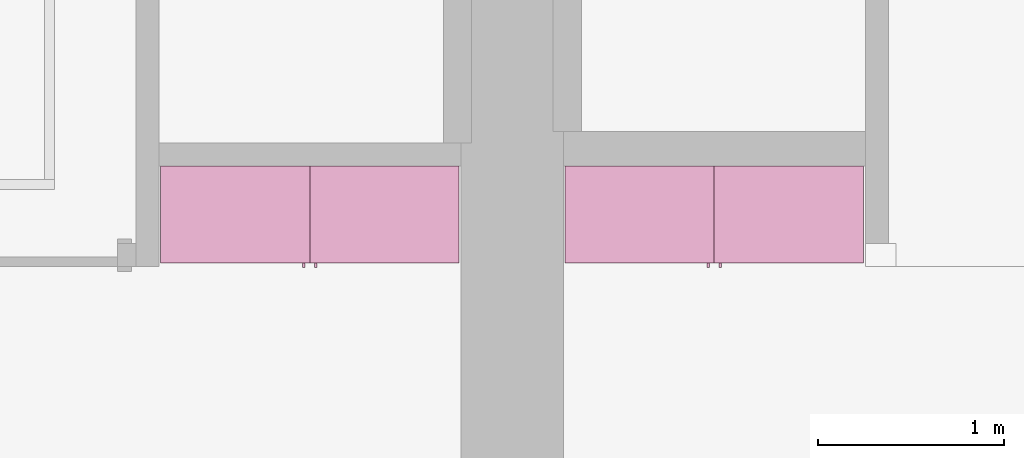
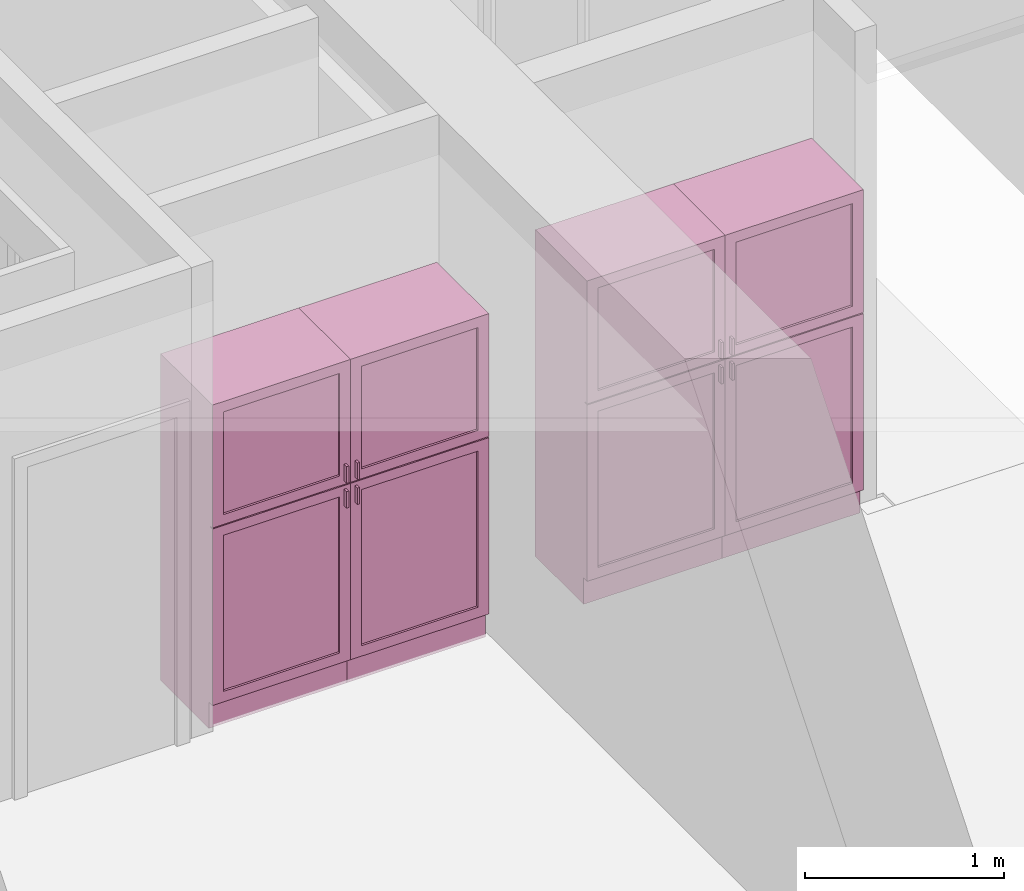
# One storey, part 11 of 12: 4 furnishings, 4 openings.
"""IFC2X3 building model written with IfcOpenShell, lengths in metres."""

import ifcopenshell
import ifcopenshell.guid

model = None  # the IFC model being written
_history = None  # IfcOwnerHistory: only IFC2X3 demands one
_inside = {}  # id of a spatial element -> (the spatial element, [elements in it])
_under = {}  # id of a project, library or spatial element -> (it, [spatial elements below it])
_declared = {}  # id of a project -> (the project, [libraries it declares])
_typed = {}  # id of a type object -> (the type object, [elements of that type])
_made_of = {}  # id of a material, layer set ... -> (it, [elements and type objects made of it])


def new_model(schema):
    """Start an empty IFC model of exactly this schema.

    Asked for "IFC4X3", IfcOpenShell would pick the latest addendum, in which some entities
    have other attributes; the version numbers below select the first issue.
    IFC2X3 requires an IfcOwnerHistory on every rooted entity: one is made here for all.
    """
    global model, _history
    if schema == "IFC4X3":
        model = ifcopenshell.file(schema_version=(4, 3, 0, 0))
    else:
        model = ifcopenshell.file(schema=schema)
    _inside.clear()
    _under.clear()
    _declared.clear()
    _typed.clear()
    _made_of.clear()
    _history = None
    if model.schema == "IFC2X3":
        org = make("IfcOrganization", Name="unknown")
        user = make(
            "IfcPersonAndOrganization",
            ThePerson=make("IfcPerson", FamilyName="unknown"),
            TheOrganization=org,
        )
        app = make(
            "IfcApplication",
            ApplicationDeveloper=org,
            Version="unknown",
            ApplicationFullName="unknown",
            ApplicationIdentifier="unknown",
        )
        _history = make(
            "IfcOwnerHistory",
            OwningUser=user,
            OwningApplication=app,
            ChangeAction="ADDED",
            CreationDate=0,
        )
    return model


def make(cls, **values):
    """One entity of the class cls with the attributes given. An attribute that is None is left unset."""
    return model.create_entity(
        cls, **{name: value for name, value in values.items() if value is not None}
    )


def entity(cls, *values):
    """Any entity or typed value of the class cls, its attributes in the order of the schema. None: left unset."""
    e = model.create_entity(cls)
    for i, value in enumerate(values):
        if value is not None:
            e[i] = value
    return e


def rooted(cls, **values):
    """An entity with a GlobalId (a new one), such as an element, a storey or a relation."""
    return make(cls, GlobalId=ifcopenshell.guid.new(), OwnerHistory=_history, **values)


def si_unit(unit_type, name, prefix=None):
    """IfcSIUnit, for example si_unit("LENGTHUNIT", "METRE", prefix="MILLI")."""
    return make("IfcSIUnit", UnitType=unit_type, Prefix=prefix, Name=name)


def converted_unit(unit_type, name, factor, base, dimensions=None, offset=None):
    """IfcConversionBasedUnit, such as the inch: factor (a typed value) times the base unit."""
    return make(
        "IfcConversionBasedUnit"
        if offset is None
        else "IfcConversionBasedUnitWithOffset",
        ConversionOffset=offset,
        Dimensions=None
        if dimensions is None
        else entity("IfcDimensionalExponents", *dimensions),
        UnitType=unit_type,
        Name=name,
        ConversionFactor=make(
            "IfcMeasureWithUnit", ValueComponent=factor, UnitComponent=base
        ),
    )


def assignment(units):
    """IfcUnitAssignment: the units of a project."""
    return None if units is None else make("IfcUnitAssignment", Units=units)


def point(xyz):
    """IfcCartesianPoint."""
    return None if xyz is None else make("IfcCartesianPoint", Coordinates=xyz)


def direction(xyz):
    """IfcDirection."""
    return None if xyz is None else make("IfcDirection", DirectionRatios=xyz)


def frame(location, z_axis=None, x_axis=None):
    """IfcAxis2Placement3D, a coordinate frame: its origin and axes. An axis left out is left unset."""
    return make(
        "IfcAxis2Placement3D",
        Location=point(location),
        Axis=direction(z_axis),
        RefDirection=direction(x_axis),
    )


def frame_2d(location, x_axis=None):
    """IfcAxis2Placement2D, a coordinate frame in the plane: its origin and x axis."""
    return make(
        "IfcAxis2Placement2D", Location=point(location), RefDirection=direction(x_axis)
    )


def origin():
    """The frame at (0, 0, 0) with its axes left unset."""
    return frame((0.0, 0.0, 0.0))


def origin_2d_with_axis():
    """The frame at (0, 0) in the plane with the x axis (1, 0) written out."""
    return frame_2d((0.0, 0.0), x_axis=(1.0, 0.0))


def place(relative_to, where):
    """IfcLocalPlacement: puts the frame where relative to a parent placement (None: the world)."""
    return make(
        "IfcLocalPlacement", PlacementRelTo=relative_to, RelativePlacement=where
    )


def context(
    kind, dimensions, precision=None, world=None, true_north=None, identifier=None
):
    """IfcGeometricRepresentationContext, for example the 3D "Model" context."""
    return make(
        "IfcGeometricRepresentationContext",
        ContextIdentifier=identifier,
        ContextType=kind,
        CoordinateSpaceDimension=dimensions,
        Precision=precision,
        WorldCoordinateSystem=world,
        TrueNorth=true_north,
    )


def project(units=None, contexts=None):
    """IfcProject with its units and contexts."""
    return rooted(
        "IfcProject",
        Name="project",
        RepresentationContexts=contexts,
        UnitsInContext=assignment(units),
    )


def spatial(cls, under=None, at=None, **own):
    """A site, building, storey or space (cls), placed at a placement, below another one or the project."""
    s = rooted(cls, ObjectPlacement=at, **own)
    if under is not None:
        _under.setdefault(under.id(), (under, []))[1].append(s)
    return s


def profile(cls, at=None, kind="AREA", **sizes):
    """A parametric profile (cls). Its sizes go by their IFC names, for example OverallWidth=200.0."""
    return make(cls, ProfileType=kind, Position=at, **sizes)


def rectangle(**sizes):
    """IfcRectangleProfileDef."""
    return profile("IfcRectangleProfileDef", **sizes)


def extrude(swept, where, along, depth):
    """IfcExtrudedAreaSolid: the profile swept, set in the frame where, extruded along a direction by depth."""
    return make(
        "IfcExtrudedAreaSolid",
        SweptArea=swept,
        Position=where,
        ExtrudedDirection=direction(along),
        Depth=depth,
    )


def faces_of(points, faces, orient=None, outer=None):
    """IfcFace entities. A face is a list of loops; a loop is a list of indices into points, from 0.

    orient and outer hold one flag for each loop. By default every Orientation is true, the
    first loop of a face is its IfcFaceOuterBound and the others are IfcFaceBound.
    """
    made = []
    for i, loops in enumerate(faces):
        bounds = []
        for j, loop in enumerate(loops):
            is_outer = j == 0 if outer is None else outer[i][j]
            bounds.append(
                make(
                    "IfcFaceOuterBound" if is_outer else "IfcFaceBound",
                    Bound=make("IfcPolyLoop", Polygon=[points[k] for k in loop]),
                    Orientation=True if orient is None else orient[i][j],
                )
            )
        made.append(make("IfcFace", Bounds=bounds))
    return made


def face_set(faces, orient=None, outer=None):
    """The faces of one IfcConnectedFaceSet. surface_model builds it on its shared points."""
    return ("IfcConnectedFaceSet", faces, orient, outer)


def surface_model(cls, points, shells):
    """IfcFaceBasedSurfaceModel or IfcShellBasedSurfaceModel (cls): surfaces that need not close."""
    shared = [point(p) for p in points]
    made = [make(c, CfsFaces=faces_of(shared, fs, o, b)) for c, fs, o, b in shells]
    if cls == "IfcFaceBasedSurfaceModel":
        return make(cls, FbsmFaces=made)
    return make(cls, SbsmBoundary=made)


def shape(context_of_items, identifier, shape_type, items):
    """IfcShapeRepresentation: the items that make up one representation, for example the "Body"."""
    return make(
        "IfcShapeRepresentation",
        ContextOfItems=context_of_items,
        RepresentationIdentifier=identifier,
        RepresentationType=shape_type,
        Items=items,
    )


def source(mapping_origin, context_of_items, identifier, shape_type, items):
    """IfcRepresentationMap: a shape defined once, which mapped items show again and again."""
    return make(
        "IfcRepresentationMap",
        MappingOrigin=mapping_origin,
        MappedRepresentation=shape(context_of_items, identifier, shape_type, items),
    )


def transform(
    local_origin,
    x_axis=None,
    y_axis=None,
    z_axis=None,
    scale=None,
    scale2=None,
    scale3=None,
    uniform=True,
):
    """IfcCartesianTransformationOperator3D, or its non-uniform kind. x_axis, y_axis, z_axis: its Axis1, 2, 3."""
    if uniform:
        return make(
            "IfcCartesianTransformationOperator3D",
            Axis1=direction(x_axis),
            Axis2=direction(y_axis),
            LocalOrigin=point(local_origin),
            Scale=scale,
            Axis3=direction(z_axis),
        )
    return make(
        "IfcCartesianTransformationOperator3DnonUniform",
        Axis1=direction(x_axis),
        Axis2=direction(y_axis),
        LocalOrigin=point(local_origin),
        Scale=scale,
        Axis3=direction(z_axis),
        Scale2=scale2,
        Scale3=scale3,
    )


def mapped(mapping_source, mapping_target):
    """IfcMappedItem: shows the shape of a source again, moved by a transform."""
    return make(
        "IfcMappedItem", MappingSource=mapping_source, MappingTarget=mapping_target
    )


def made_of(thing, what):
    """Note that an element or type object is made of a material, layer set ...; save() writes the relation."""
    if what is not None:
        _made_of.setdefault(what.id(), (what, []))[1].append(thing)
    return thing


def type_object(cls, material=None, **own):
    """A type object (cls), such as IfcWallType, which elements share."""
    return made_of(rooted(cls, **own), material)


def type_shapes(of_type, sources):
    """Give a type object the sources (RepresentationMaps) that its elements show as mapped items."""
    of_type.RepresentationMaps = sources


def element(
    cls,
    number,
    at=None,
    inside=None,
    cuts=None,
    type_object=None,
    material=None,
    context=None,
    identifier="Body",
    shape_type=None,
    held_by="IfcProductDefinitionShape",
    body=None,
    shapes=None,
    **own,
):
    """One element of the class cls, such as IfcWall. Its Tag is "e" and its number.

    at: its placement. inside: the storey or other place that contains it. cuts: it is an
    opening in that element (IfcRelVoidsElement). A single representation is given by context,
    identifier, shape_type and body (its items); several are given by shapes. held_by: the class
    of the entity that holds the representations. save() writes the other relations.
    """
    e = rooted(cls, Tag="e%d" % number, ObjectPlacement=at, **own)
    if body is not None:
        shapes = [shape(context, identifier, shape_type, body)]
    if shapes is not None:
        e.Representation = make(held_by, Representations=shapes)
    if inside is not None:
        _inside.setdefault(inside.id(), (inside, []))[1].append(e)
    if cuts is not None:
        rooted(
            "IfcRelVoidsElement", RelatingBuildingElement=cuts, RelatedOpeningElement=e
        )
    if type_object is not None:
        _typed.setdefault(type_object.id(), (type_object, []))[1].append(e)
    return made_of(e, material)


def aggregate(whole, parts):
    """IfcRelAggregates: a whole, such as a stair, and the parts it consists of."""
    return rooted("IfcRelAggregates", RelatingObject=whole, RelatedObjects=parts)


def save(model, path):
    """Write the relations noted so far, then the file.

    IfcRelAggregates (storeys below a building ...), IfcRelContainedInSpatialStructure (elements
    in a storey), IfcRelDefinesByType, IfcRelAssociatesMaterial and IfcRelDeclares: one each for
    every whole, place, type object, material and project.
    """
    for whole, parts in _under.values():
        aggregate(whole, parts)
    for where, things in _inside.values():
        rooted(
            "IfcRelContainedInSpatialStructure",
            RelatedElements=things,
            RelatingStructure=where,
        )
    for kind, things in _typed.values():
        rooted("IfcRelDefinesByType", RelatedObjects=things, RelatingType=kind)
    for what, things in _made_of.values():
        rooted("IfcRelAssociatesMaterial", RelatedObjects=things, RelatingMaterial=what)
    for by, libraries in _declared.values():
        rooted("IfcRelDeclares", RelatingContext=by, RelatedDefinitions=libraries)
    model.write(path)


model = new_model("IFC2X3")

# Units and contexts
model_context = context("Model", 3, precision=1e-09, world=origin())
plan_context = context("Plan", 3, precision=1e-09, world=origin())
ifc_project = project(units=[si_unit("LENGTHUNIT", "METRE"), si_unit("AREAUNIT", "SQUARE_METRE"), si_unit("VOLUMEUNIT", "CUBIC_METRE"), converted_unit("PLANEANGLEUNIT", "DEGREE", entity("IfcRatioMeasure", 0.0174532925199433), si_unit("PLANEANGLEUNIT", "RADIAN"), dimensions=[0, 0, 0, 0, 0, 0, 0]), si_unit("TIMEUNIT", "SECOND")], contexts=[model_context, plan_context])

# Site, building, storey, space
site_placement = place(None, origin())
site = spatial("IfcSite", under=ifc_project, at=site_placement, CompositionType="ELEMENT")
building_placement = place(site_placement, origin())
building = spatial("IfcBuilding", under=site, at=building_placement, CompositionType="ELEMENT")
storey_placement = place(building_placement, frame((0.0, 0.0, 3.10000000000038)))
storey = spatial("IfcBuildingStorey", under=building, at=storey_placement, Name="Level 2", CompositionType="ELEMENT", Elevation=3.10000000000038)
space_1_placement = place(storey_placement, origin())
space_1 = spatial("IfcSpace", under=storey, at=space_1_placement, CompositionType="ELEMENT", InteriorOrExteriorSpace="INTERNAL")

# Furnishing, opening
furniture_type_1 = type_object("IfcFurnitureType", Name="800 mm", AssemblyPlace="NOTDEFINED")
shared_shape_1 = source(origin(), model_context, "Body", "SurfaceModel", [
    surface_model("IfcFaceBasedSurfaceModel", [(0.8, 0.0444499999999999, 0.161587499999842), (0.0, 0.0444500000000025, 0.161587499999842), (0.0, 0.0444500000000025, 2.0), (0.8, 0.0444499999999999, 2.0), (0.780949999999997, 0.04445, 1.98094999999995), (0.0190499999999982, 0.0444500000000025, 1.98094999999995), (0.0190499999999982, 0.0444500000000025, 0.180637499999843), (0.780949999999997, 0.04445, 0.180637499999843), (0.0, 0.545400000000002, 2.0), (0.800000000000001, 0.5454, 2.0), (0.800000000000003, 0.5454, 0.0), (0.0, 0.545400000000001, 0.0), (0.780949999999999, 0.5454, 1.98094999999995), (0.0190499999999998, 0.545400000000002, 1.98094999999995), (0.0190499999999998, 0.545400000000002, 0.180637499999843), (0.780949999999999, 0.5454, 0.180637499999843), (0.8, 0.0604000000000018, 0.161587499999842), (0.8, 0.0604000000000018, 0.0), (0.0, 0.0604000000000018, 0.0), (0.0, 0.0604000000000018, 0.161587499999832), (0.7746, 0.0, 1.37154803669582), (0.7746, 0.0, 1.26994803669581), (0.762067768369355, 0.0, 1.26994803669581), (0.762067768369355, 0.0, 1.37154803669582), (0.774599999999999, 0.0, 1.21914803669582), (0.774599999999999, 0.0, 1.11754803669582), (0.762067768369354, 0.0, 1.11754803669582), (0.762067768369354, 0.0, 1.21914803669582), (0.7746, 0.0254, 1.37154803669582), (0.7746, 0.0254, 1.26994803669581), (0.762067768369356, 0.0254000000000001, 1.26994803669581), (0.762067768369356, 0.0254000000000001, 1.37154803669582), (0.774599999999999, 0.0254, 1.21914803669582), (0.774599999999999, 0.0254, 1.11754803669582), (0.762067768369354, 0.0254000000000001, 1.11754803669582), (0.762067768369354, 0.0254000000000001, 1.21914803669582), (0.7365, 0.0381000000000001, 1.93649999999996), (0.7365, 0.0381000000000001, 1.30804803669582), (0.0635000000000013, 0.0381000000000023, 1.30804803669582), (0.0635000000000013, 0.0381000000000023, 1.93649999999996), (0.736499999999999, 0.0381000000000001, 1.18104803669581), (0.736499999999999, 0.0381000000000001, 0.22508749999984), (0.0635000000000007, 0.0381000000000023, 0.22508749999984), (0.0635000000000007, 0.0381000000000023, 1.18104803669581), (0.7365, 0.0444500000000001, 1.93649999999996), (0.7365, 0.0444500000000001, 1.30804803669582), (0.0635000000000013, 0.0444500000000023, 1.30804803669582), (0.0635000000000013, 0.0444500000000023, 1.93649999999996), (0.736499999999999, 0.0444500000000001, 1.18104803669581), (0.736499999999999, 0.0444500000000001, 0.22508749999984), (0.0635000000000007, 0.0444500000000023, 0.22508749999984), (0.0635000000000007, 0.0444500000000023, 1.18104803669581), (0.8, 0.0253999999999998, 2.0), (0.8, 0.0253999999999998, 1.24772303669581), (0.0, 0.0254000000000025, 1.24772303669581), (0.0, 0.0254000000000025, 2.0), (0.7365, 0.0254000000000001, 1.93649999999996), (0.0635000000000012, 0.0254000000000023, 1.93649999999996), (0.0635000000000012, 0.0254000000000023, 1.30804803669582), (0.7365, 0.0254000000000001, 1.30804803669582), (0.8, 0.0253999999999998, 0.161587499999821), (0.0, 0.0254000000000025, 0.161587499999821), (0.0, 0.0254000000000025, 1.24137303669581), (0.8, 0.0253999999999998, 1.24137303669581), (0.736499999999999, 0.0254000000000001, 1.18104803669582), (0.0635000000000007, 0.0254000000000023, 1.18104803669582), (0.0635000000000007, 0.0254000000000023, 0.22508749999984), (0.736499999999999, 0.0254000000000001, 0.22508749999984), (0.8, 0.0444499999999998, 2.0), (0.8, 0.0444499999999998, 1.24772303669581), (0.0, 0.0444500000000025, 1.24772303669581), (0.0, 0.0444500000000025, 2.0), (0.7365, 0.0444500000000001, 1.93649999999996), (0.0635000000000013, 0.0444500000000023, 1.93649999999996), (0.0635000000000013, 0.0444500000000023, 1.30804803669582), (0.7365, 0.0444500000000001, 1.30804803669582), (0.8, 0.0444499999999998, 0.161587499999821), (0.0, 0.0444500000000025, 0.161587499999821), (0.0, 0.0444500000000025, 1.24137303669581), (0.8, 0.0444499999999998, 1.24137303669581), (0.736499999999999, 0.0444500000000001, 1.18104803669582), (0.0635000000000007, 0.0444500000000023, 1.18104803669582), (0.0635000000000007, 0.0444500000000023, 0.22508749999984), (0.736499999999999, 0.0444500000000001, 0.22508749999984), (0.780949999999999, 0.526350000000001, 1.98094999999995), (0.780949999999999, 0.526350000000001, 0.180637499999846), (0.0190499999999999, 0.526350000000001, 0.180637499999846), (0.0190499999999998, 0.526350000000001, 1.98094999999995), (0.780949999999999, 0.545400000000001, 1.98094999999995), (0.780949999999999, 0.545400000000001, 0.180637499999846), (0.0190499999999998, 0.545400000000001, 0.180637499999846), (0.0190499999999998, 0.545400000000001, 1.98094999999995)], [face_set([[[0, 1, 2, 3], [4, 5, 6, 7]], [[8, 9, 10, 11], [12, 13, 14, 15]], [[3, 0, 16, 17, 10, 9]], [[2, 8, 9, 3]], [[1, 2, 8, 11, 18, 19]], [[0, 1, 19, 16]], [[7, 15, 12, 4]], [[6, 14, 15, 7]], [[5, 13, 14, 6]], [[4, 5, 13, 12]], [[10, 17, 18, 11]], [[18, 19, 16, 17]]]), face_set([[[20, 21, 22, 23]], [[24, 25, 26, 27]], [[28, 29, 30, 31]], [[32, 33, 34, 35]], [[23, 31, 28, 20]], [[22, 23, 31, 30]], [[21, 22, 30, 29]], [[20, 28, 29, 21]], [[27, 35, 32, 24]], [[26, 27, 35, 34]], [[25, 26, 34, 33]], [[24, 32, 33, 25]]]), face_set([[[36, 37, 38, 39]], [[40, 41, 42, 43]], [[44, 45, 46, 47]], [[48, 49, 50, 51]], [[39, 47, 44, 36]], [[38, 46, 47, 39]], [[37, 38, 46, 45]], [[36, 37, 45, 44]], [[43, 51, 48, 40]], [[42, 50, 51, 43]], [[41, 42, 50, 49]], [[40, 41, 49, 48]]]), face_set([[[52, 53, 54, 55], [56, 57, 58, 59]], [[60, 61, 62, 63], [64, 65, 66, 67]], [[68, 69, 70, 71], [72, 73, 74, 75]], [[76, 77, 78, 79], [80, 81, 82, 83]], [[55, 71, 68, 52]], [[54, 55, 71, 70]], [[53, 54, 70, 69]], [[52, 53, 69, 68]], [[63, 60, 76, 79]], [[62, 78, 79, 63]], [[61, 62, 78, 77]], [[60, 61, 77, 76]], [[59, 75, 72, 56]], [[58, 74, 75, 59]], [[57, 58, 74, 73]], [[56, 57, 73, 72]], [[67, 83, 80, 64]], [[66, 82, 83, 67]], [[65, 66, 82, 81]], [[64, 65, 81, 80]]]), face_set([[[84, 85, 86, 87]], [[88, 89, 90, 91]], [[87, 91, 88, 84]], [[86, 87, 91, 90]], [[85, 86, 90, 89]], [[84, 85, 89, 88]]])]),
])
type_shapes(furniture_type_1, [shared_shape_1])
furnishing_1_placement = place(space_1_placement, frame((2.51399999999999, -11.6794, 0.0)))
furnishing_1 = element("IfcFurnishingElement", 1, at=furnishing_1_placement, inside=space_1, type_object=furniture_type_1, ObjectType="800 mm", context=model_context, shape_type="MappedRepresentation", body=[
    mapped(shared_shape_1, transform((0.0, 0.0, 0.0), scale=1.0)),
])
opening_1_placement = place(space_1_placement, frame((2.51399999999999, -11.6794, 0.0)))
element("IfcOpeningElement", 2, at=opening_1_placement, cuts=furnishing_1, ObjectType="Opening", context=model_context, shape_type="SweptSolid", body=[
    extrude(rectangle(XDim=1.80031250000011, YDim=0.761899999999999, at=origin_2d_with_axis()), frame((0.0187377049180235, -0.50095, -2.01920625000048), z_axis=(0.0, 1.0, 0.0), x_axis=(0.0, 0.0, -1.0)), (0.0, 0.0, 1.0), 0.50095),
])

furniture_type_2 = type_object("IfcFurnitureType", Name="800 mm", AssemblyPlace="NOTDEFINED")
shared_shape_2 = source(origin(), model_context, "Body", "SurfaceModel", [
    surface_model("IfcFaceBasedSurfaceModel", [(0.8, 0.500950000000002, 0.161587499999842), (0.8, 0.500950000000002, 2.0), (0.0, 0.50095, 2.0), (0.0, 0.50095, 0.161587499999842), (0.780949999999997, 0.500950000000002, 1.98094999999995), (0.780949999999997, 0.500950000000002, 0.180637499999843), (0.0190499999999982, 0.50095, 0.180637499999843), (0.0190499999999982, 0.50095, 1.98094999999995), (0.0, 0.0, 2.0), (0.0, 0.0, 0.0), (0.800000000000003, 0.0, 0.0), (0.800000000000001, 0.0, 2.0), (0.780949999999999, 0.0, 1.98094999999995), (0.780949999999999, 0.0, 0.180637499999843), (0.0190499999999998, 0.0, 0.180637499999843), (0.0190499999999998, 0.0, 1.98094999999995), (0.800000000000003, 0.485, 0.0), (0.8, 0.485, 0.161587499999832), (0.0, 0.485, 0.0), (0.0, 0.485, 0.161587499999842), (0.7746, 0.545400000000002, 1.37154803669582), (0.762067768369355, 0.545400000000002, 1.37154803669582), (0.762067768369355, 0.545400000000002, 1.26994803669581), (0.7746, 0.545400000000002, 1.26994803669581), (0.774599999999999, 0.545400000000002, 1.21914803669582), (0.762067768369354, 0.545400000000002, 1.21914803669582), (0.762067768369354, 0.545400000000002, 1.11754803669582), (0.774599999999999, 0.545400000000002, 1.11754803669582), (0.7746, 0.520000000000002, 1.37154803669582), (0.762067768369356, 0.520000000000002, 1.37154803669582), (0.762067768369356, 0.520000000000002, 1.26994803669581), (0.7746, 0.520000000000002, 1.26994803669581), (0.774599999999999, 0.520000000000002, 1.21914803669582), (0.762067768369354, 0.520000000000002, 1.21914803669582), (0.762067768369354, 0.520000000000002, 1.11754803669582), (0.774599999999999, 0.520000000000002, 1.11754803669582), (0.7365, 0.507300000000002, 1.93649999999996), (0.0635000000000013, 0.5073, 1.93649999999996), (0.0635000000000013, 0.5073, 1.30804803669582), (0.7365, 0.507300000000002, 1.30804803669582), (0.736499999999999, 0.507300000000002, 1.18104803669581), (0.0635000000000007, 0.5073, 1.18104803669581), (0.0635000000000007, 0.5073, 0.22508749999984), (0.736499999999999, 0.507300000000002, 0.22508749999984), (0.7365, 0.500950000000002, 1.93649999999996), (0.0635000000000013, 0.50095, 1.93649999999996), (0.0635000000000013, 0.50095, 1.30804803669582), (0.7365, 0.500950000000002, 1.30804803669582), (0.736499999999999, 0.500950000000002, 1.18104803669581), (0.0635000000000007, 0.50095, 1.18104803669581), (0.0635000000000007, 0.50095, 0.22508749999984), (0.736499999999999, 0.500950000000002, 0.22508749999984), (0.8, 0.520000000000002, 2.0), (0.0, 0.52, 2.0), (0.0, 0.52, 1.24772303669581), (0.8, 0.520000000000002, 1.24772303669581), (0.7365, 0.520000000000002, 1.93649999999996), (0.7365, 0.520000000000002, 1.30804803669582), (0.0635000000000012, 0.52, 1.30804803669582), (0.0635000000000012, 0.52, 1.93649999999996), (0.8, 0.520000000000002, 0.161587499999821), (0.8, 0.520000000000002, 1.24137303669581), (0.0, 0.52, 1.24137303669581), (0.0, 0.52, 0.161587499999821), (0.736499999999999, 0.520000000000002, 1.18104803669582), (0.736499999999999, 0.520000000000002, 0.22508749999984), (0.0635000000000007, 0.52, 0.22508749999984), (0.0635000000000007, 0.52, 1.18104803669582), (0.8, 0.500950000000002, 2.0), (0.0, 0.50095, 2.0), (0.0, 0.50095, 1.24772303669581), (0.8, 0.500950000000002, 1.24772303669581), (0.7365, 0.500950000000002, 1.93649999999996), (0.7365, 0.500950000000002, 1.30804803669582), (0.0635000000000013, 0.50095, 1.30804803669582), (0.0635000000000013, 0.50095, 1.93649999999996), (0.8, 0.500950000000002, 0.161587499999821), (0.8, 0.500950000000002, 1.24137303669581), (0.0, 0.50095, 1.24137303669581), (0.0, 0.50095, 0.161587499999821), (0.736499999999999, 0.500950000000002, 1.18104803669582), (0.736499999999999, 0.500950000000002, 0.22508749999984), (0.0635000000000007, 0.50095, 0.22508749999984), (0.0635000000000007, 0.50095, 1.18104803669582), (0.780949999999999, 0.0190500000000013, 1.98094999999995), (0.0190499999999998, 0.0190500000000013, 1.98094999999995), (0.0190499999999998, 0.0190500000000013, 0.180637499999846), (0.780949999999999, 0.0190500000000013, 0.180637499999846), (0.780949999999999, 0.0, 1.98094999999995), (0.0190499999999998, 0.0, 1.98094999999995), (0.0190499999999999, 0.0, 0.180637499999846), (0.780949999999999, 0.0, 0.180637499999846)], [face_set([[[0, 1, 2, 3], [4, 5, 6, 7]], [[8, 9, 10, 11], [12, 13, 14, 15]], [[1, 11, 10, 16, 17, 0]], [[2, 1, 11, 8]], [[3, 2, 8, 9, 18, 19]], [[0, 17, 19, 3]], [[5, 4, 12, 13]], [[6, 5, 13, 14]], [[7, 6, 14, 15]], [[4, 12, 15, 7]], [[10, 9, 18, 16]], [[18, 16, 17, 19]]]), face_set([[[20, 21, 22, 23]], [[24, 25, 26, 27]], [[28, 29, 30, 31]], [[32, 33, 34, 35]], [[21, 20, 28, 29]], [[22, 30, 29, 21]], [[23, 31, 30, 22]], [[20, 23, 31, 28]], [[25, 24, 32, 33]], [[26, 34, 33, 25]], [[27, 35, 34, 26]], [[24, 27, 35, 32]]]), face_set([[[36, 37, 38, 39]], [[40, 41, 42, 43]], [[44, 45, 46, 47]], [[48, 49, 50, 51]], [[37, 36, 44, 45]], [[38, 37, 45, 46]], [[39, 47, 46, 38]], [[36, 44, 47, 39]], [[41, 40, 48, 49]], [[42, 41, 49, 50]], [[43, 51, 50, 42]], [[40, 48, 51, 43]]]), face_set([[[52, 53, 54, 55], [56, 57, 58, 59]], [[60, 61, 62, 63], [64, 65, 66, 67]], [[68, 69, 70, 71], [72, 73, 74, 75]], [[76, 77, 78, 79], [80, 81, 82, 83]], [[53, 52, 68, 69]], [[54, 70, 69, 53]], [[55, 71, 70, 54]], [[52, 68, 71, 55]], [[61, 77, 76, 60]], [[62, 61, 77, 78]], [[63, 79, 78, 62]], [[60, 76, 79, 63]], [[57, 56, 72, 73]], [[58, 57, 73, 74]], [[59, 75, 74, 58]], [[56, 72, 75, 59]], [[65, 64, 80, 81]], [[66, 65, 81, 82]], [[67, 83, 82, 66]], [[64, 80, 83, 67]]]), face_set([[[84, 85, 86, 87]], [[88, 89, 90, 91]], [[85, 84, 88, 89]], [[86, 90, 89, 85]], [[87, 91, 90, 86]], [[84, 88, 91, 87]]])]),
])
type_shapes(furniture_type_2, [shared_shape_2])
furnishing_2_placement = place(space_1_placement, frame((4.11399999999999, -11.134, 0.0), z_axis=(0.0, 0.0, 1.0), x_axis=(-1.0, 0.0, 0.0)))
furnishing_2 = element("IfcFurnishingElement", 3, at=furnishing_2_placement, inside=space_1, type_object=furniture_type_2, ObjectType="800 mm", context=model_context, shape_type="MappedRepresentation", body=[
    mapped(shared_shape_2, transform((0.0, 0.0, 0.0), scale=1.0)),
])
opening_2_placement = place(space_1_placement, frame((4.11399999999999, -11.134, 0.0), z_axis=(0.0, 0.0, 1.0), x_axis=(-1.0, 0.0, 0.0)))
element("IfcOpeningElement", 4, at=opening_2_placement, cuts=furnishing_2, ObjectType="Opening", context=model_context, shape_type="SweptSolid", body=[
    extrude(rectangle(XDim=1.80031250000011, YDim=0.761899999999999, at=origin_2d_with_axis()), frame((-0.0187377049180251, 0.0, -2.01920625000048), z_axis=(0.0, -1.0, 0.0), x_axis=(0.0, 0.0, -1.0)), (0.0, 0.0, 1.0), 0.50095),
])

# Space
space_2_placement = place(storey_placement, origin())
space_2 = spatial("IfcSpace", under=storey, at=space_2_placement, CompositionType="ELEMENT", InteriorOrExteriorSpace="INTERNAL")

# Furnishing, opening
furniture_type_3 = type_object("IfcFurnitureType", Name="800 mm", AssemblyPlace="NOTDEFINED")
shared_shape_3 = source(origin(), model_context, "Body", "SurfaceModel", [
    surface_model("IfcFaceBasedSurfaceModel", [(0.8, 0.0444499999999999, 0.161587499999842), (0.0, 0.0444500000000025, 0.161587499999842), (0.0, 0.0444500000000025, 2.0), (0.8, 0.0444499999999999, 2.0), (0.780949999999997, 0.04445, 1.98094999999995), (0.0190499999999982, 0.0444500000000025, 1.98094999999995), (0.0190499999999982, 0.0444500000000025, 0.180637499999843), (0.780949999999997, 0.04445, 0.180637499999843), (0.0, 0.545400000000002, 2.0), (0.800000000000001, 0.5454, 2.0), (0.800000000000003, 0.5454, 0.0), (0.0, 0.545400000000001, 0.0), (0.780949999999999, 0.5454, 1.98094999999995), (0.0190499999999998, 0.545400000000002, 1.98094999999995), (0.0190499999999998, 0.545400000000002, 0.180637499999843), (0.780949999999999, 0.5454, 0.180637499999843), (0.8, 0.0604000000000018, 0.161587499999842), (0.8, 0.0604000000000018, 0.0), (0.0, 0.0604000000000018, 0.0), (0.0, 0.0604000000000018, 0.161587499999832), (0.7746, 0.0, 1.37154803669582), (0.7746, 0.0, 1.26994803669581), (0.762067768369355, 0.0, 1.26994803669581), (0.762067768369355, 0.0, 1.37154803669582), (0.774599999999999, 0.0, 1.21914803669582), (0.774599999999999, 0.0, 1.11754803669582), (0.762067768369354, 0.0, 1.11754803669582), (0.762067768369354, 0.0, 1.21914803669582), (0.7746, 0.0254, 1.37154803669582), (0.7746, 0.0254, 1.26994803669581), (0.762067768369356, 0.0254000000000001, 1.26994803669581), (0.762067768369356, 0.0254000000000001, 1.37154803669582), (0.774599999999999, 0.0254, 1.21914803669582), (0.774599999999999, 0.0254, 1.11754803669582), (0.762067768369354, 0.0254000000000001, 1.11754803669582), (0.762067768369354, 0.0254000000000001, 1.21914803669582), (0.7365, 0.0381000000000001, 1.93649999999996), (0.7365, 0.0381000000000001, 1.30804803669582), (0.0635000000000013, 0.0381000000000023, 1.30804803669582), (0.0635000000000013, 0.0381000000000023, 1.93649999999996), (0.736499999999999, 0.0381000000000001, 1.18104803669581), (0.736499999999999, 0.0381000000000001, 0.22508749999984), (0.0635000000000007, 0.0381000000000023, 0.22508749999984), (0.0635000000000007, 0.0381000000000023, 1.18104803669581), (0.7365, 0.0444500000000001, 1.93649999999996), (0.7365, 0.0444500000000001, 1.30804803669582), (0.0635000000000013, 0.0444500000000023, 1.30804803669582), (0.0635000000000013, 0.0444500000000023, 1.93649999999996), (0.736499999999999, 0.0444500000000001, 1.18104803669581), (0.736499999999999, 0.0444500000000001, 0.22508749999984), (0.0635000000000007, 0.0444500000000023, 0.22508749999984), (0.0635000000000007, 0.0444500000000023, 1.18104803669581), (0.8, 0.0253999999999998, 2.0), (0.8, 0.0253999999999998, 1.24772303669581), (0.0, 0.0254000000000025, 1.24772303669581), (0.0, 0.0254000000000025, 2.0), (0.7365, 0.0254000000000001, 1.93649999999996), (0.0635000000000012, 0.0254000000000023, 1.93649999999996), (0.0635000000000012, 0.0254000000000023, 1.30804803669582), (0.7365, 0.0254000000000001, 1.30804803669582), (0.8, 0.0253999999999998, 0.161587499999821), (0.0, 0.0254000000000025, 0.161587499999821), (0.0, 0.0254000000000025, 1.24137303669581), (0.8, 0.0253999999999998, 1.24137303669581), (0.736499999999999, 0.0254000000000001, 1.18104803669582), (0.0635000000000007, 0.0254000000000023, 1.18104803669582), (0.0635000000000007, 0.0254000000000023, 0.22508749999984), (0.736499999999999, 0.0254000000000001, 0.22508749999984), (0.8, 0.0444499999999998, 2.0), (0.8, 0.0444499999999998, 1.24772303669581), (0.0, 0.0444500000000025, 1.24772303669581), (0.0, 0.0444500000000025, 2.0), (0.7365, 0.0444500000000001, 1.93649999999996), (0.0635000000000013, 0.0444500000000023, 1.93649999999996), (0.0635000000000013, 0.0444500000000023, 1.30804803669582), (0.7365, 0.0444500000000001, 1.30804803669582), (0.8, 0.0444499999999998, 0.161587499999821), (0.0, 0.0444500000000025, 0.161587499999821), (0.0, 0.0444500000000025, 1.24137303669581), (0.8, 0.0444499999999998, 1.24137303669581), (0.736499999999999, 0.0444500000000001, 1.18104803669582), (0.0635000000000007, 0.0444500000000023, 1.18104803669582), (0.0635000000000007, 0.0444500000000023, 0.22508749999984), (0.736499999999999, 0.0444500000000001, 0.22508749999984), (0.780949999999999, 0.526350000000001, 1.98094999999995), (0.780949999999999, 0.526350000000001, 0.180637499999846), (0.0190499999999999, 0.526350000000001, 0.180637499999846), (0.0190499999999998, 0.526350000000001, 1.98094999999995), (0.780949999999999, 0.545400000000001, 1.98094999999995), (0.780949999999999, 0.545400000000001, 0.180637499999846), (0.0190499999999998, 0.545400000000001, 0.180637499999846), (0.0190499999999998, 0.545400000000001, 1.98094999999995)], [face_set([[[0, 1, 2, 3], [4, 5, 6, 7]], [[8, 9, 10, 11], [12, 13, 14, 15]], [[3, 0, 16, 17, 10, 9]], [[2, 8, 9, 3]], [[1, 2, 8, 11, 18, 19]], [[0, 1, 19, 16]], [[7, 15, 12, 4]], [[6, 14, 15, 7]], [[5, 13, 14, 6]], [[4, 5, 13, 12]], [[10, 17, 18, 11]], [[18, 19, 16, 17]]]), face_set([[[20, 21, 22, 23]], [[24, 25, 26, 27]], [[28, 29, 30, 31]], [[32, 33, 34, 35]], [[23, 31, 28, 20]], [[22, 23, 31, 30]], [[21, 22, 30, 29]], [[20, 28, 29, 21]], [[27, 35, 32, 24]], [[26, 27, 35, 34]], [[25, 26, 34, 33]], [[24, 32, 33, 25]]]), face_set([[[36, 37, 38, 39]], [[40, 41, 42, 43]], [[44, 45, 46, 47]], [[48, 49, 50, 51]], [[39, 47, 44, 36]], [[38, 46, 47, 39]], [[37, 38, 46, 45]], [[36, 37, 45, 44]], [[43, 51, 48, 40]], [[42, 50, 51, 43]], [[41, 42, 50, 49]], [[40, 41, 49, 48]]]), face_set([[[52, 53, 54, 55], [56, 57, 58, 59]], [[60, 61, 62, 63], [64, 65, 66, 67]], [[68, 69, 70, 71], [72, 73, 74, 75]], [[76, 77, 78, 79], [80, 81, 82, 83]], [[55, 71, 68, 52]], [[54, 55, 71, 70]], [[53, 54, 70, 69]], [[52, 53, 69, 68]], [[63, 60, 76, 79]], [[62, 78, 79, 63]], [[61, 62, 78, 77]], [[60, 61, 77, 76]], [[59, 75, 72, 56]], [[58, 74, 75, 59]], [[57, 58, 74, 73]], [[56, 57, 73, 72]], [[67, 83, 80, 64]], [[66, 82, 83, 67]], [[65, 66, 82, 81]], [[64, 65, 81, 80]]]), face_set([[[84, 85, 86, 87]], [[88, 89, 90, 91]], [[87, 91, 88, 84]], [[86, 87, 91, 90]], [[85, 86, 90, 89]], [[84, 85, 89, 88]]])]),
])
type_shapes(furniture_type_3, [shared_shape_3])
furnishing_3_placement = place(space_2_placement, frame((4.68299999999998, -11.6794, 0.0)))
furnishing_3 = element("IfcFurnishingElement", 5, at=furnishing_3_placement, inside=space_2, type_object=furniture_type_3, ObjectType="800 mm", context=model_context, shape_type="MappedRepresentation", body=[
    mapped(shared_shape_3, transform((0.0, 0.0, 0.0), scale=1.0)),
])
opening_3_placement = place(space_2_placement, frame((4.68299999999998, -11.6794, 0.0)))
element("IfcOpeningElement", 6, at=opening_3_placement, cuts=furnishing_3, ObjectType="Opening", context=model_context, shape_type="SweptSolid", body=[
    extrude(rectangle(XDim=1.80031250000011, YDim=0.761899999999999, at=origin_2d_with_axis()), frame((0.0187377049180235, -0.50095, -2.01920625000048), z_axis=(0.0, 1.0, 0.0), x_axis=(0.0, 0.0, -1.0)), (0.0, 0.0, 1.0), 0.50095),
])

furniture_type_4 = type_object("IfcFurnitureType", Name="800 mm", AssemblyPlace="NOTDEFINED")
shared_shape_4 = source(origin(), model_context, "Body", "SurfaceModel", [
    surface_model("IfcFaceBasedSurfaceModel", [(0.8, 0.500950000000002, 0.161587499999842), (0.8, 0.500950000000002, 2.0), (0.0, 0.50095, 2.0), (0.0, 0.50095, 0.161587499999842), (0.780949999999997, 0.500950000000002, 1.98094999999995), (0.780949999999997, 0.500950000000002, 0.180637499999843), (0.0190499999999982, 0.50095, 0.180637499999843), (0.0190499999999982, 0.50095, 1.98094999999995), (0.0, 0.0, 2.0), (0.0, 0.0, 0.0), (0.800000000000003, 0.0, 0.0), (0.800000000000001, 0.0, 2.0), (0.780949999999999, 0.0, 1.98094999999995), (0.780949999999999, 0.0, 0.180637499999843), (0.0190499999999998, 0.0, 0.180637499999843), (0.0190499999999998, 0.0, 1.98094999999995), (0.800000000000003, 0.485, 0.0), (0.8, 0.485, 0.161587499999832), (0.0, 0.485, 0.0), (0.0, 0.485, 0.161587499999842), (0.7746, 0.545400000000002, 1.37154803669582), (0.762067768369355, 0.545400000000002, 1.37154803669582), (0.762067768369355, 0.545400000000002, 1.26994803669581), (0.7746, 0.545400000000002, 1.26994803669581), (0.774599999999999, 0.545400000000002, 1.21914803669582), (0.762067768369354, 0.545400000000002, 1.21914803669582), (0.762067768369354, 0.545400000000002, 1.11754803669582), (0.774599999999999, 0.545400000000002, 1.11754803669582), (0.7746, 0.520000000000002, 1.37154803669582), (0.762067768369356, 0.520000000000002, 1.37154803669582), (0.762067768369356, 0.520000000000002, 1.26994803669581), (0.7746, 0.520000000000002, 1.26994803669581), (0.774599999999999, 0.520000000000002, 1.21914803669582), (0.762067768369354, 0.520000000000002, 1.21914803669582), (0.762067768369354, 0.520000000000002, 1.11754803669582), (0.774599999999999, 0.520000000000002, 1.11754803669582), (0.7365, 0.507300000000002, 1.93649999999996), (0.0635000000000013, 0.5073, 1.93649999999996), (0.0635000000000013, 0.5073, 1.30804803669582), (0.7365, 0.507300000000002, 1.30804803669582), (0.736499999999999, 0.507300000000002, 1.18104803669581), (0.0635000000000007, 0.5073, 1.18104803669581), (0.0635000000000007, 0.5073, 0.22508749999984), (0.736499999999999, 0.507300000000002, 0.22508749999984), (0.7365, 0.500950000000002, 1.93649999999996), (0.0635000000000013, 0.50095, 1.93649999999996), (0.0635000000000013, 0.50095, 1.30804803669582), (0.7365, 0.500950000000002, 1.30804803669582), (0.736499999999999, 0.500950000000002, 1.18104803669581), (0.0635000000000007, 0.50095, 1.18104803669581), (0.0635000000000007, 0.50095, 0.22508749999984), (0.736499999999999, 0.500950000000002, 0.22508749999984), (0.8, 0.520000000000002, 2.0), (0.0, 0.52, 2.0), (0.0, 0.52, 1.24772303669581), (0.8, 0.520000000000002, 1.24772303669581), (0.7365, 0.520000000000002, 1.93649999999996), (0.7365, 0.520000000000002, 1.30804803669582), (0.0635000000000012, 0.52, 1.30804803669582), (0.0635000000000012, 0.52, 1.93649999999996), (0.8, 0.520000000000002, 0.161587499999821), (0.8, 0.520000000000002, 1.24137303669581), (0.0, 0.52, 1.24137303669581), (0.0, 0.52, 0.161587499999821), (0.736499999999999, 0.520000000000002, 1.18104803669582), (0.736499999999999, 0.520000000000002, 0.22508749999984), (0.0635000000000007, 0.52, 0.22508749999984), (0.0635000000000007, 0.52, 1.18104803669582), (0.8, 0.500950000000002, 2.0), (0.0, 0.50095, 2.0), (0.0, 0.50095, 1.24772303669581), (0.8, 0.500950000000002, 1.24772303669581), (0.7365, 0.500950000000002, 1.93649999999996), (0.7365, 0.500950000000002, 1.30804803669582), (0.0635000000000013, 0.50095, 1.30804803669582), (0.0635000000000013, 0.50095, 1.93649999999996), (0.8, 0.500950000000002, 0.161587499999821), (0.8, 0.500950000000002, 1.24137303669581), (0.0, 0.50095, 1.24137303669581), (0.0, 0.50095, 0.161587499999821), (0.736499999999999, 0.500950000000002, 1.18104803669582), (0.736499999999999, 0.500950000000002, 0.22508749999984), (0.0635000000000007, 0.50095, 0.22508749999984), (0.0635000000000007, 0.50095, 1.18104803669582), (0.780949999999999, 0.0190500000000013, 1.98094999999995), (0.0190499999999998, 0.0190500000000013, 1.98094999999995), (0.0190499999999998, 0.0190500000000013, 0.180637499999846), (0.780949999999999, 0.0190500000000013, 0.180637499999846), (0.780949999999999, 0.0, 1.98094999999995), (0.0190499999999998, 0.0, 1.98094999999995), (0.0190499999999999, 0.0, 0.180637499999846), (0.780949999999999, 0.0, 0.180637499999846)], [face_set([[[0, 1, 2, 3], [4, 5, 6, 7]], [[8, 9, 10, 11], [12, 13, 14, 15]], [[1, 11, 10, 16, 17, 0]], [[2, 1, 11, 8]], [[3, 2, 8, 9, 18, 19]], [[0, 17, 19, 3]], [[5, 4, 12, 13]], [[6, 5, 13, 14]], [[7, 6, 14, 15]], [[4, 12, 15, 7]], [[10, 9, 18, 16]], [[18, 16, 17, 19]]]), face_set([[[20, 21, 22, 23]], [[24, 25, 26, 27]], [[28, 29, 30, 31]], [[32, 33, 34, 35]], [[21, 20, 28, 29]], [[22, 30, 29, 21]], [[23, 31, 30, 22]], [[20, 23, 31, 28]], [[25, 24, 32, 33]], [[26, 34, 33, 25]], [[27, 35, 34, 26]], [[24, 27, 35, 32]]]), face_set([[[36, 37, 38, 39]], [[40, 41, 42, 43]], [[44, 45, 46, 47]], [[48, 49, 50, 51]], [[37, 36, 44, 45]], [[38, 37, 45, 46]], [[39, 47, 46, 38]], [[36, 44, 47, 39]], [[41, 40, 48, 49]], [[42, 41, 49, 50]], [[43, 51, 50, 42]], [[40, 48, 51, 43]]]), face_set([[[52, 53, 54, 55], [56, 57, 58, 59]], [[60, 61, 62, 63], [64, 65, 66, 67]], [[68, 69, 70, 71], [72, 73, 74, 75]], [[76, 77, 78, 79], [80, 81, 82, 83]], [[53, 52, 68, 69]], [[54, 70, 69, 53]], [[55, 71, 70, 54]], [[52, 68, 71, 55]], [[61, 77, 76, 60]], [[62, 61, 77, 78]], [[63, 79, 78, 62]], [[60, 76, 79, 63]], [[57, 56, 72, 73]], [[58, 57, 73, 74]], [[59, 75, 74, 58]], [[56, 72, 75, 59]], [[65, 64, 80, 81]], [[66, 65, 81, 82]], [[67, 83, 82, 66]], [[64, 80, 83, 67]]]), face_set([[[84, 85, 86, 87]], [[88, 89, 90, 91]], [[85, 84, 88, 89]], [[86, 90, 89, 85]], [[87, 91, 90, 86]], [[84, 88, 91, 87]]])]),
])
type_shapes(furniture_type_4, [shared_shape_4])
furnishing_4_placement = place(space_2_placement, frame((6.28299999999999, -11.134, 0.0), z_axis=(0.0, 0.0, 1.0), x_axis=(-1.0, 0.0, 0.0)))
furnishing_4 = element("IfcFurnishingElement", 7, at=furnishing_4_placement, inside=space_2, type_object=furniture_type_4, ObjectType="800 mm", context=model_context, shape_type="MappedRepresentation", body=[
    mapped(shared_shape_4, transform((0.0, 0.0, 0.0), scale=1.0)),
])
opening_4_placement = place(space_2_placement, frame((6.28299999999999, -11.134, 0.0), z_axis=(0.0, 0.0, 1.0), x_axis=(-1.0, 0.0, 0.0)))
element("IfcOpeningElement", 8, at=opening_4_placement, cuts=furnishing_4, ObjectType="Opening", context=model_context, shape_type="SweptSolid", body=[
    extrude(rectangle(XDim=1.80031250000011, YDim=0.761899999999999, at=origin_2d_with_axis()), frame((-0.0187377049180251, 0.0, -2.01920625000048), z_axis=(0.0, -1.0, 0.0), x_axis=(0.0, 0.0, -1.0)), (0.0, 0.0, 1.0), 0.50095),
])

save(model, "model.ifc")
